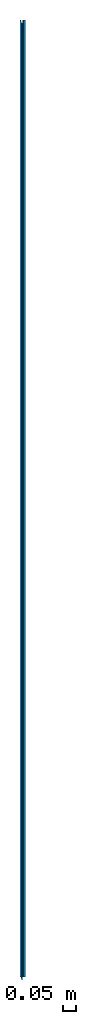
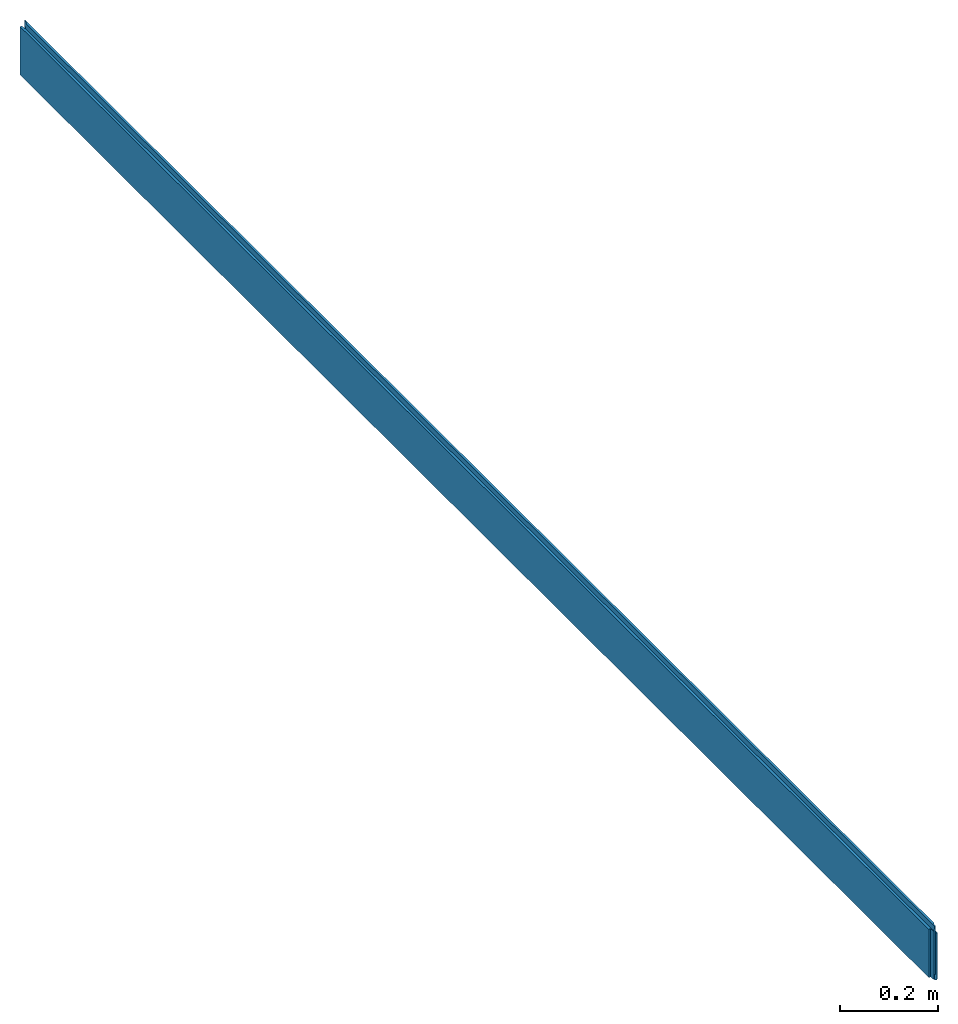
# One storey: 1 beam.
"""IFC2X3 building model written with IfcOpenShell, lengths in metres."""

from ifc_helpers import new_model, si_unit, frame, origin_with_axes, place, context, project, spatial, faceted_brep, material, element, save


model = new_model("IFC2X3")

# Units and contexts
model_context = context("Model", 3, precision=1e-06, world=origin_with_axes())
ifc_project = project(units=[si_unit("LENGTHUNIT", "METRE"), si_unit("PLANEANGLEUNIT", "RADIAN")], contexts=[model_context])

# Site, building, storey
site_placement = place(None, origin_with_axes())
site = spatial("IfcSite", under=ifc_project, at=site_placement, CompositionType="ELEMENT")
building_placement = place(None, origin_with_axes())
building = spatial("IfcBuilding", under=site, at=building_placement, Name="Building 1", CompositionType="ELEMENT")
storey_placement = place(None, origin_with_axes())
storey = spatial("IfcBuildingStorey", under=building, at=storey_placement, CompositionType="ELEMENT", Elevation=0.0)

# Beam
ifc_material = material()
beam_placement = place(None, frame((0.010499999999984, 3.699999999999998, 0.06000000000202), z_axis=(-1.0, 0.0, 0.0), x_axis=(0.0, -1.0, 1.6e-14)))
element("IfcBeam", 1, at=beam_placement, inside=storey, material=ifc_material, context=model_context, shape_type="Brep", body=[
    faceted_brep([(0.011500000000012, 0.060000000000032, 0.005148503727051), (0.011500000000011, -0.059999999999968, 0.005148503727051), (0.0, -0.059999999999968, 0.006298503727018), (2e-15, 0.060000000000032, 0.006298503727018), (0.011500000000012, 0.060000000000032, 0.004800000000003), (0.011500000000013, 0.072000000000068, 0.003600000000024), (0.011500000000013, 0.072000000000054, 0.001051496267203), (0.011500000000011, -0.047999999999943, 0.001051496267203), (0.011500000000011, -0.047999999999928, 0.003600000000026), (0.011500000000011, -0.059999999999968, 0.004800000000003), (0.011500000000011, -0.059999999999968, 0.005148503727051), (0.011500000000012, 0.060000000000032, 0.005148503727051), (2e-15, 0.072000000000048, -9.8503732729e-05), (0.0, -0.04799999999995, -9.8503732729e-05), (0.011500000000011, -0.047999999999943, 0.001051496267203), (0.011500000000013, 0.072000000000054, 0.001051496267203), (0.0, -0.059999999999968, 0.006298503727018), (0.011500000000011, -0.059999999999968, 0.005148503727051), (0.011500000000011, -0.059999999999968, 0.004800000000003), (3.711500000000006, -0.060000000000028, 0.004800000000003), (3.711500000000006, -0.060000000000028, 0.005148503727051), (3.699999999999977, -0.060000000000028, 0.00629850372702), (3.699999999999998, -0.060000000000028, 0.010499999999984), (0.0, -0.059999999999968, 0.010499999999984), (0.011500000000011, -0.059999999999968, 0.004800000000003), (0.011500000000011, -0.047999999999928, 0.003600000000026), (3.711500000000006, -0.047999999999988, 0.003600000000026), (3.711500000000006, -0.060000000000028, 0.004800000000003), (0.011500000000011, -0.047999999999928, 0.003600000000026), (0.011500000000011, -0.047999999999943, 0.001051496267203), (0.0, -0.04799999999995, -9.8503732729e-05), (0.0, -0.047999999999959, -0.001599999999978), (3.700000000000001, -0.048000000000019, -0.001599999999978), (3.700000000000001, -0.04800000000001, -9.8503732716e-05), (3.711500000000006, -0.048000000000003, 0.001051496267202), (3.711500000000006, -0.047999999999988, 0.003600000000026), (0.0, -0.04799999999995, -9.8503732729e-05), (2e-15, 0.072000000000048, -9.8503732729e-05), (2e-15, 0.07200000000004, -0.001599999999978), (2e-15, 0.045679491924393, -0.004232050807375), (2e-15, 0.044401923788323, -0.00900000000133), (0.0, -0.072000000000013, -0.008999999999938), (0.0, -0.072000000000013, -0.007999999983072), (0.0, -0.070898693820087, -0.003889869381848), (0.0, -0.047999999999959, -0.001599999999978), (2e-15, 0.060000000000032, 0.006298503727018), (0.0, -0.059999999999968, 0.006298503727018), (0.0, -0.059999999999968, 0.010499999999984), (2e-15, 0.060000000000032, 0.010499999999982), (0.0, -0.072000000000013, -0.008999999999938), (2e-15, 0.044401923788323, -0.00900000000133), (0.001499999998655, 0.044000000000038, -0.010499999999983), (0.001499999998611, -0.070500000000013, -0.010499999999941), (2e-15, 0.044401923788323, -0.00900000000133), (2e-15, 0.045679491924393, -0.004232050807375), (3.700000000000003, 0.045679491924332, -0.004232050807375), (3.700000000000003, 0.044401923788263, -0.00900000000133), (3.698500000001347, 0.043999999999978, -0.010499999999983), (0.001499999998655, 0.044000000000038, -0.010499999999983), (2e-15, 0.07200000000004, -0.001599999999978), (3.700000000000003, 0.071999999999979, -0.001599999999978), (3.700000000000003, 0.045679491924332, -0.004232050807375), (2e-15, 0.045679491924393, -0.004232050807375), (0.011500000000013, 0.072000000000054, 0.001051496267203), (0.011500000000013, 0.072000000000068, 0.003600000000024), (3.711500000000008, 0.072000000000008, 0.003600000000024), (3.711500000000008, 0.071999999999994, 0.001051496267202), (3.700000000000003, 0.071999999999988, -9.8503732716e-05), (3.700000000000003, 0.071999999999979, -0.001599999999978), (2e-15, 0.07200000000004, -0.001599999999978), (2e-15, 0.072000000000048, -9.8503732729e-05), (0.011500000000013, 0.072000000000068, 0.003600000000024), (0.011500000000012, 0.060000000000032, 0.004800000000003), (3.711500000000008, 0.059999999999972, 0.004800000000003), (3.711500000000008, 0.072000000000008, 0.003600000000024), (0.011500000000012, 0.060000000000032, 0.005148503727051), (2e-15, 0.060000000000032, 0.006298503727018), (2e-15, 0.060000000000032, 0.010499999999982), (3.7, 0.059999999999972, 0.010499999999982), (3.699999999999979, 0.059999999999972, 0.00629850372702), (3.711500000000008, 0.059999999999972, 0.005148503727051), (3.711500000000008, 0.059999999999972, 0.004800000000003), (0.011500000000012, 0.060000000000032, 0.004800000000003), (0.0, -0.059999999999968, 0.010499999999984), (3.699999999999998, -0.060000000000028, 0.010499999999984), (3.7, 0.059999999999972, 0.010499999999982), (2e-15, 0.060000000000032, 0.010499999999982), (3.698499999999998, -0.070499999998684, -0.01050000000133), (3.698500000001347, 0.043999999999978, -0.010499999999983), (3.700000000000003, 0.044401923788263, -0.00900000000133), (3.700000000000001, -0.072000000000073, -0.00900000000133), (3.700000000000001, -0.072000000000073, -0.00900000000133), (3.700000000000003, 0.044401923788263, -0.00900000000133), (3.700000000000003, 0.045679491924332, -0.004232050807375), (3.700000000000003, 0.071999999999979, -0.001599999999978), (3.700000000000003, 0.071999999999988, -9.8503732716e-05), (3.700000000000001, -0.04800000000001, -9.8503732716e-05), (3.700000000000001, -0.048000000000019, -0.001599999999978), (3.700000000000001, -0.070898693820147, -0.003889869381848), (3.700000000000001, -0.072000000000073, -0.007999999983072), (3.711500000000008, 0.071999999999994, 0.001051496267202), (3.711500000000006, -0.048000000000003, 0.001051496267202), (3.700000000000001, -0.04800000000001, -9.8503732716e-05), (3.700000000000003, 0.071999999999988, -9.8503732716e-05), (0.001499999998611, -0.070500000000013, -0.010499999999941), (3.698499999999998, -0.070499999998684, -0.01050000000133), (3.700000000000001, -0.072000000000073, -0.00900000000133), (0.0, -0.072000000000013, -0.008999999999938), (0.0, -0.072000000000013, -0.008999999999938), (3.700000000000001, -0.072000000000073, -0.00900000000133), (3.700000000000001, -0.072000000000073, -0.007999999983072), (0.0, -0.072000000000013, -0.007999999983072), (0.0, -0.072000000000013, -0.007999999983072), (3.700000000000001, -0.072000000000073, -0.007999999983072), (3.700000000000001, -0.070898693820147, -0.003889869381848), (0.0, -0.070898693820087, -0.003889869381848), (0.0, -0.070898693820087, -0.003889869381848), (3.700000000000001, -0.070898693820147, -0.003889869381848), (3.700000000000001, -0.048000000000019, -0.001599999999978), (0.0, -0.047999999999959, -0.001599999999978), (3.699999999999979, 0.059999999999972, 0.00629850372702), (3.699999999999977, -0.060000000000028, 0.00629850372702), (3.711500000000006, -0.060000000000028, 0.005148503727051), (3.711500000000008, 0.059999999999972, 0.005148503727051), (3.7, 0.059999999999972, 0.010499999999982), (3.699999999999998, -0.060000000000028, 0.010499999999984), (3.699999999999977, -0.060000000000028, 0.00629850372702), (3.699999999999979, 0.059999999999972, 0.00629850372702), (3.711500000000006, -0.048000000000003, 0.001051496267202), (3.711500000000008, 0.071999999999994, 0.001051496267202), (3.711500000000008, 0.072000000000008, 0.003600000000024), (3.711500000000008, 0.059999999999972, 0.004800000000003), (3.711500000000008, 0.059999999999972, 0.005148503727051), (3.711500000000006, -0.060000000000028, 0.005148503727051), (3.711500000000006, -0.060000000000028, 0.004800000000003), (3.711500000000006, -0.047999999999988, 0.003600000000026), (0.001499999998655, 0.044000000000038, -0.010499999999983), (3.698500000001347, 0.043999999999978, -0.010499999999983), (3.698499999999998, -0.070499999998684, -0.01050000000133), (0.001499999998611, -0.070500000000013, -0.010499999999941)], [[[0, 1, 2, 3]], [[4, 5, 6, 7, 8, 9, 10, 11]], [[12, 13, 14, 15]], [[16, 17, 18, 19, 20, 21, 22, 23]], [[24, 25, 26, 27]], [[28, 29, 30, 31, 32, 33, 34, 35]], [[36, 37, 38, 39, 40, 41, 42, 43, 44]], [[45, 46, 47, 48]], [[49, 50, 51, 52]], [[53, 54, 55, 56, 57, 58]], [[59, 60, 61, 62]], [[63, 64, 65, 66, 67, 68, 69, 70]], [[71, 72, 73, 74]], [[75, 76, 77, 78, 79, 80, 81, 82]], [[83, 84, 85, 86]], [[87, 88, 89, 90]], [[91, 92, 93, 94, 95, 96, 97, 98, 99]], [[100, 101, 102, 103]], [[104, 105, 106, 107]], [[108, 109, 110, 111]], [[112, 113, 114, 115]], [[116, 117, 118, 119]], [[120, 121, 122, 123]], [[124, 125, 126, 127]], [[128, 129, 130, 131, 132, 133, 134, 135]], [[136, 137, 138, 139]]]),
])

save(model, "model.ifc")
